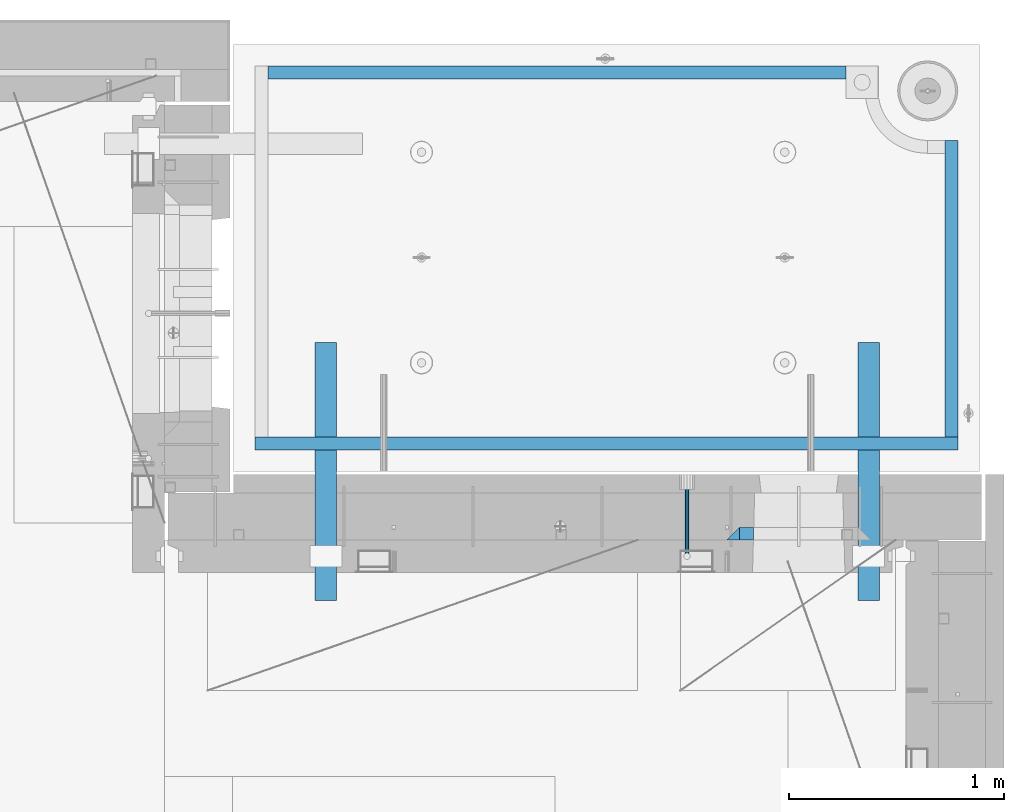
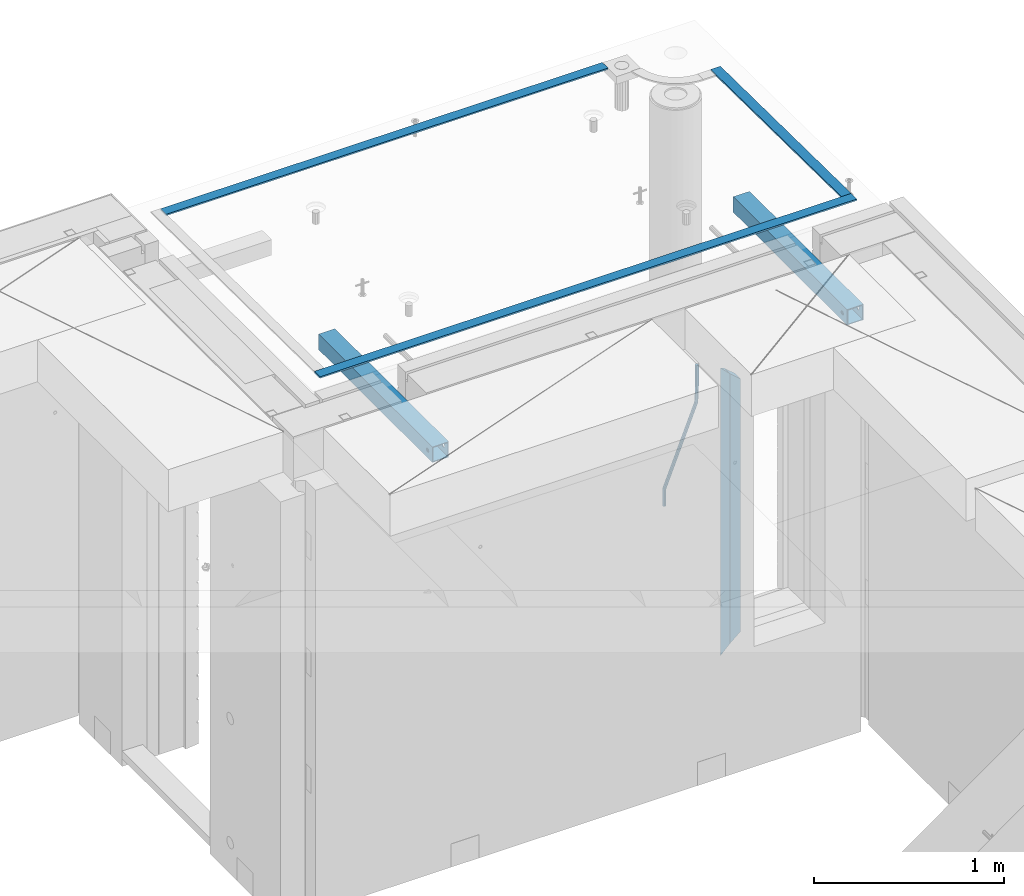
# One storey, part 130 of 341: 8 beams, 4 elements without a shape of their own.
"""IFC2X3 building model written with IfcOpenShell, lengths in millimetres."""

from ifc_helpers import new_model, si_unit, frame, origin_with_axes, place, context, subcontext, project, spatial, faceted_brep, material, type_object, element, aggregate, save


model = new_model("IFC2X3")

# Units and contexts
model_context = context("Model", 3, precision=1e-05, world=origin_with_axes())
body_context = subcontext(model_context, "Body", "Model", "MODEL_VIEW")
ifc_project = project(units=[si_unit("LENGTHUNIT", "METRE", prefix="MILLI"), si_unit("AREAUNIT", "SQUARE_METRE"), si_unit("VOLUMEUNIT", "CUBIC_METRE"), si_unit("MASSUNIT", "GRAM", prefix="KILO"), si_unit("TIMEUNIT", "SECOND"), si_unit("PLANEANGLEUNIT", "RADIAN"), si_unit("SOLIDANGLEUNIT", "STERADIAN"), si_unit("THERMODYNAMICTEMPERATUREUNIT", "DEGREE_CELSIUS"), si_unit("LUMINOUSINTENSITYUNIT", "LUMEN")], contexts=[model_context])

# Site, building, storey
site_placement = place(None, origin_with_axes())
site = spatial("IfcSite", under=ifc_project, at=site_placement, CompositionType="ELEMENT")
building_placement = place(site_placement, origin_with_axes())
building = spatial("IfcBuilding", under=site, at=building_placement, CompositionType="ELEMENT")
storey_placement = place(building_placement, origin_with_axes())
storey = spatial("IfcBuildingStorey", under=building, at=storey_placement, Name="5", CompositionType="ELEMENT", Elevation=0.0)

# Assembly, beam
assembly_1_placement = place(storey_placement, origin_with_axes())
assembly_1 = element("IfcElementAssembly", 1, at=assembly_1_placement, inside=storey, AssemblyPlace="NOTDEFINED", PredefinedType="REINFORCEMENT_UNIT")
ifc_material_1 = material()
beam_type_1 = type_object("IfcBeamType", Name="D20", PredefinedType="NOTDEFINED")
beam_1_placement = place(assembly_1_placement, frame((33889.995187329, 20504.9951872346, 96407.5), z_axis=(0.000415599999849905, 0.999999913638203, 4.76000000899737e-07), x_axis=(0.0, 0.0, -1.0)))
beam_1 = element("IfcBeam", 2, at=beam_1_placement, type_object=beam_type_1, material=ifc_material_1, Name="JM20", ObjectType="D20", context=body_context, shape_type="Brep", body=[
    faceted_brep([(-0.00060564729210455, -9.99999998165731, 0.0), (-0.000428079845733009, -7.07106779890455, -7.07106781186667), (119.575515501536, -7.07830994756296, -7.07106481604933), (119.575337932896, -10.0072421307195, -3.43332612828817e-06), (0.0, 0.0, -10.0), (119.575943836026, -0.00724214867295814, -9.99999700418266), (0.00042843479604926, 7.07106779888636, -7.07106781186303), (119.57637202373, 7.06382565022977, -7.07106481604933), (0.00060564729210455, 9.99999998166459, 3.63797880709171e-12), (119.576549238118, 9.99275783300072, 2.99581552098971e-06), (0.000428079845733009, 7.07106779890819, 7.07106781186667), (119.576371669405, 7.06382565024978, 7.07107080768037), (0.0, 0.0, 10.0), (119.57594333493, -0.00724214864203532, 10.0000029958155), (-0.000428434810601175, -7.07106779888272, 7.07106781186667), (119.575515147211, -7.07830994754295, 7.07107080768037), (123.00654325854, -7.07836650239551, -6.96786008391246), (122.581588830741, -10.007295666459, 0.0904344953341933), (123.182419066041, -0.00729994480025198, -9.89151006310021), (123.006190977103, 7.06376911688858, -6.96788735351402), (122.581091016109, 9.99270432680532, 0.0903895128230943), (122.156136974867, 7.06377516229986, 7.14867767459873), (121.980261167351, -0.00729139528993983, 10.0723276537792), (122.156489256289, -7.07836045697513, 7.14870494419847), (237.077376207715, -7.07551629289992, -0.0988779924864502), (236.652422053201, -10.0044409119728, 6.95941204931296), (237.253252288647, -0.0044516184279928, -3.02253250974718), (237.077024472936, 7.06661932641327, -0.0989143382521434), (236.651924624995, 9.99555908263574, 6.95936064834314), (236.226970470365, 7.06663446442326, 14.0176506898479), (236.051094389448, -0.0044302100486675, 16.9413052071086), (236.227322205144, -7.07550115488812, 14.0176870356117), (256.715938387759, -7.07353516174771, 4.66794781703175), (253.858321224223, -10.0027051854922, 11.1357628166734), (257.898622435067, -0.00236892073007766, 1.98867362452802), (256.713573090979, 7.0686002544353, 4.66742272414376), (253.85497618909, 9.99729452004976, 11.1350202234971), (250.997359025234, 7.06812449537756, 17.6028352234607), (249.814674977912, -0.00304174564189452, 20.2821094159572), (250.999724322028, -7.07401092080545, 17.6033603163596), (1009.84102825288, -6.93521658215468, 337.477148757798), (1006.98341108896, -9.86438660663771, 343.944963757851), (1011.02371230032, 0.135949658781101, 334.7978745651), (1009.83866295629, 7.20691883402651, 337.476623664521), (1006.98006605446, 10.1356130998429, 343.944221163818), (1004.12244889054, 7.2064430753635, 350.412036163872), (1002.9397648431, 0.135276834424076, 353.091310356571), (1004.12481418712, -6.93569234081951, 350.412561257146), (1010.86335274603, -6.9350288225487, 337.928918327354), (1009.37086865908, -9.86394812736762, 344.999991477531), (1011.48104818776, 0.136033652863262, 334.999973251377), (1010.86211737194, 7.20710680115553, 337.928892551665), (1009.36912157628, 10.1360518725905, 344.9999550252), (1007.87663748935, 7.2071325677698, 352.071028175378), (1007.2589420476, 0.13607009235966, 354.999973251352), (1007.87787286344, -6.93500305593261, 352.071053951067), (1011.98104820926, -6.93502881915083, 337.92891832735), (1011.98104821818, -9.86394811943501, 344.999991477524), (1011.98104818776, 0.136033654382118, 334.999973251375), (1011.98104816627, 7.20710680455704, 337.928892551661), (1011.98104815738, 10.1360518805304, 344.999955025194), (1011.98104816629, 7.20713258024625, 352.071028175369), (1011.98104818778, 0.136070106711486, 354.999973251342), (1011.98104820927, -6.9350030434598, 352.071053951058), (1117.50000002154, -6.93502849844299, 337.928918327156), (1117.50000003044, -9.86394779872717, 344.999991477331), (1117.50000000004, 0.136033975091777, 334.999973251181), (1117.49999997855, 7.20710712526488, 337.928892551467), (1117.49999996964, 10.1360522012383, 344.999955025), (1117.49999997857, 7.20713290095409, 352.071028175174), (1117.50000000006, 0.136070427419327, 354.999973251148), (1117.50000002155, -6.93500272275196, 352.071053950864)], [[[0, 1, 2, 3]], [[1, 4, 5, 2]], [[4, 6, 7, 5]], [[6, 8, 9, 7]], [[8, 10, 11, 9]], [[10, 12, 13, 11]], [[12, 14, 15, 13]], [[14, 0, 3, 15]], [[14, 12, 10, 8, 6, 4, 1, 0]], [[3, 2, 16, 17]], [[2, 5, 18, 16]], [[5, 7, 19, 18]], [[7, 9, 20, 19]], [[9, 11, 21, 20]], [[11, 13, 22, 21]], [[13, 15, 23, 22]], [[15, 3, 17, 23]], [[17, 16, 24, 25]], [[16, 18, 26, 24]], [[18, 19, 27, 26]], [[19, 20, 28, 27]], [[20, 21, 29, 28]], [[21, 22, 30, 29]], [[22, 23, 31, 30]], [[23, 17, 25, 31]], [[25, 24, 32, 33]], [[24, 26, 34, 32]], [[26, 27, 35, 34]], [[27, 28, 36, 35]], [[28, 29, 37, 36]], [[29, 30, 38, 37]], [[30, 31, 39, 38]], [[31, 25, 33, 39]], [[33, 32, 40, 41]], [[32, 34, 42, 40]], [[34, 35, 43, 42]], [[35, 36, 44, 43]], [[36, 37, 45, 44]], [[37, 38, 46, 45]], [[38, 39, 47, 46]], [[39, 33, 41, 47]], [[41, 40, 48, 49]], [[40, 42, 50, 48]], [[42, 43, 51, 50]], [[43, 44, 52, 51]], [[44, 45, 53, 52]], [[45, 46, 54, 53]], [[46, 47, 55, 54]], [[47, 41, 49, 55]], [[49, 48, 56, 57]], [[48, 50, 58, 56]], [[50, 51, 59, 58]], [[51, 52, 60, 59]], [[52, 53, 61, 60]], [[53, 54, 62, 61]], [[54, 55, 63, 62]], [[55, 49, 57, 63]], [[57, 56, 64, 65]], [[56, 58, 66, 64]], [[58, 59, 67, 66]], [[59, 60, 68, 67]], [[60, 61, 69, 68]], [[61, 62, 70, 69]], [[62, 63, 71, 70]], [[63, 57, 65, 71]], [[66, 67, 68, 69, 70, 71, 65, 64]]]),
])

# Assemblies, beams
assembly_2_placement = place(storey_placement, origin_with_axes())
assembly_2 = element("IfcElementAssembly", 3, at=assembly_2_placement, inside=storey, AssemblyPlace="NOTDEFINED", PredefinedType="REINFORCEMENT_UNIT")
assembly_3_placement = place(assembly_2_placement, origin_with_axes())
assembly_3 = element("IfcElementAssembly", 4, at=assembly_3_placement, AssemblyPlace="NOTDEFINED", PredefinedType="NOTDEFINED")
ifc_material_2 = material(Name="Undefined/350")
beam_type_2 = type_object("IfcBeamType", Name="100X100X5", PredefinedType="NOTDEFINED")
beam_2_placement = place(assembly_3_placement, frame((34735.0001432011, 21500.0034426031, 96555.0), z_axis=(0.0, 0.0, 1.0), x_axis=(-2.2242999997242e-05, -0.999999999752625, 0.0)))
beam_2 = element("IfcBeam", 5, at=beam_2_placement, type_object=beam_type_2, material=ifc_material_2, ObjectType="100X100X5", context=body_context, shape_type="Brep", body=[
    faceted_brep([(1143.75108023171, 44.9999999999982, -10.8253175473074), (1143.75107855316, 50.0255964196231, -10.8253175473074), (1139.17576100585, 50.0255948914664, -6.25), (1139.1757626844, 44.9999999999982, -6.25), (1150.00108023171, 44.9999999999982, -12.5), (1150.00107855316, 50.0255985071226, -12.5), (1156.2510802317, 44.9999999999982, -10.8253175473074), (1156.25107855315, 50.0256005946221, -10.8253175473074), (1160.82639777901, 44.9999999999982, -6.25), (1160.82639610046, 50.0256021227788, -6.25), (1162.50108023171, 44.9999999999982, 0.0), (1162.50107855316, 50.0256026821226, 0.0), (1160.82639777901, 44.9999999999982, 6.25), (1160.82639610046, 50.0256021227788, 6.25), (1156.2510802317, 44.9999999999982, 10.8253175473074), (1156.25107855315, 50.0256005946221, 10.8253175473074), (1150.00108023171, 44.9999999999982, 12.5), (1150.00107855316, 50.0255985071226, 12.5), (1143.75108023171, 44.9999999999982, 10.8253175473074), (1143.75107855316, 50.0255964196231, 10.8253175473074), (1139.1757626844, 44.9999999999982, 6.25), (1139.17576100585, 50.0255948914664, 6.25), (1137.5010802317, 44.9999999999982, 0.0), (1137.50107855316, 50.0255943321226, 0.0), (1143.75111195316, -49.9744035792783, -10.8253175473074), (1143.75111029171, -44.9999999999991, -10.8253175473074), (1139.1757927444, -44.9999999999991, -6.25), (1139.17579440585, -49.9744051074349, -6.25), (1150.00111195316, -49.9744014917787, -12.5), (1150.00111029171, -44.9999999999991, -12.5), (1156.25111195316, -49.9743994042774, -10.8253175473074), (1156.25111029171, -44.9999999999991, -10.8253175473074), (1160.82642950046, -49.9743978761207, -6.25), (1160.82642783901, -44.9999999999991, -6.25), (1162.50111195316, -49.9743973167779, 0.0), (1162.50111029171, -44.9999999999991, 0.0), (1160.82642950046, -49.9743978761207, 6.25), (1160.82642783901, -44.9999999999991, 6.25), (1156.25111195316, -49.9743994042774, 10.8253175473074), (1156.25111029171, -44.9999999999991, 10.8253175473074), (1150.00111195316, -49.9744014917787, 12.5), (1150.00111029171, -44.9999999999991, 12.5), (1143.75111195316, -49.9744035792783, 10.8253175473074), (1143.75111029171, -44.9999999999991, 10.8253175473074), (1139.17579440585, -49.9744051074349, 6.25), (1139.1757927444, -44.9999999999991, 6.25), (1137.50111195316, -49.9744056667778, 0.0), (1137.50111029171, -44.9999999999991, 0.0), (1.81898940354586e-12, -50.0000000000009, -50.0), (1.81898940354586e-12, 49.9999999999991, -50.0), (1200.00449189278, 49.9999999999982, -50.0), (1200.00449189278, -50.0000000000009, -50.0), (1.81898940354586e-12, 49.9999999999991, 50.0), (1.81898940354586e-12, -50.0000000000009, 50.0), (1200.00449189278, -50.0000000000009, 50.0), (1200.00449189278, 49.9999999999982, 50.0), (0.0, 44.9999999999991, 45.0), (1.81898940354586e-12, -45.0000000000009, 45.0), (1.81898940354586e-12, -45.0000000000009, -45.0), (0.0, 44.9999999999991, -45.0), (1200.00449189278, 44.9999999999982, -45.0), (1200.00449189278, 44.9999999999982, 45.0), (1200.00449189278, -45.0000000000009, 45.0), (1200.00449189278, -45.0000000000009, -45.0)], [[[0, 1, 2, 3]], [[4, 5, 1, 0]], [[6, 7, 5, 4]], [[8, 9, 7, 6]], [[10, 11, 9, 8]], [[12, 13, 11, 10]], [[14, 15, 13, 12]], [[16, 17, 15, 14]], [[18, 19, 17, 16]], [[20, 21, 19, 18]], [[22, 23, 21, 20]], [[3, 2, 23, 22]], [[24, 25, 26, 27]], [[28, 29, 25, 24]], [[30, 31, 29, 28]], [[32, 33, 31, 30]], [[34, 35, 33, 32]], [[36, 37, 35, 34]], [[38, 39, 37, 36]], [[40, 41, 39, 38]], [[42, 43, 41, 40]], [[44, 45, 43, 42]], [[46, 47, 45, 44]], [[27, 26, 47, 46]], [[48, 49, 50, 51]], [[52, 53, 54, 55]], [[49, 52, 55, 50], [15, 17, 19, 21, 23, 2, 1, 5, 7, 9, 11, 13]], [[48, 53, 52, 49], [56, 57, 58, 59]], [[56, 59, 60, 61], [6, 4, 0, 3, 22, 20, 18, 16, 14, 12, 10, 8]], [[57, 56, 61, 62]], [[58, 57, 62, 63], [39, 41, 43, 45, 47, 26, 25, 29, 31, 33, 35, 37]], [[59, 58, 63, 60]], [[54, 51, 50, 55], [62, 61, 60, 63]], [[53, 48, 51, 54], [30, 28, 24, 27, 46, 44, 42, 40, 38, 36, 34, 32]]]),
])
aggregate(assembly_3, [beam_2])
assembly_4_placement = place(assembly_2_placement, origin_with_axes())
assembly_4 = element("IfcElementAssembly", 6, at=assembly_4_placement, AssemblyPlace="NOTDEFINED", PredefinedType="NOTDEFINED")
beam_3_placement = place(assembly_4_placement, frame((32210.0001432011, 21500.0034426031, 96555.0), z_axis=(0.0, 0.0, 1.0), x_axis=(-2.2242999997242e-05, -0.999999999752625, 0.0)))
beam_3 = element("IfcBeam", 7, at=beam_3_placement, type_object=beam_type_2, material=ifc_material_2, ObjectType="100X100X5", context=body_context, shape_type="Brep", body=[
    faceted_brep([(1143.75108023171, 44.9999999999982, -10.8253175473074), (1143.75107855316, 50.0255964196231, -10.8253175473074), (1139.17576100585, 50.0255948914664, -6.25), (1139.1757626844, 44.9999999999982, -6.25), (1150.00108023171, 44.9999999999982, -12.5), (1150.00107855316, 50.0255985071226, -12.5), (1156.2510802317, 44.9999999999982, -10.8253175473074), (1156.25107855315, 50.0256005946221, -10.8253175473074), (1160.82639777901, 44.9999999999982, -6.25), (1160.82639610046, 50.0256021227788, -6.25), (1162.50108023171, 44.9999999999982, 0.0), (1162.50107855316, 50.0256026821226, 0.0), (1160.82639777901, 44.9999999999982, 6.25), (1160.82639610046, 50.0256021227788, 6.25), (1156.2510802317, 44.9999999999982, 10.8253175473074), (1156.25107855315, 50.0256005946221, 10.8253175473074), (1150.00108023171, 44.9999999999982, 12.5), (1150.00107855316, 50.0255985071226, 12.5), (1143.75108023171, 44.9999999999982, 10.8253175473074), (1143.75107855316, 50.0255964196231, 10.8253175473074), (1139.1757626844, 44.9999999999982, 6.25), (1139.17576100585, 50.0255948914664, 6.25), (1137.5010802317, 44.9999999999982, 0.0), (1137.50107855316, 50.0255943321226, 0.0), (1143.75111195316, -49.9744035792783, -10.8253175473074), (1143.75111029171, -44.9999999999991, -10.8253175473074), (1139.1757927444, -44.9999999999991, -6.25), (1139.17579440585, -49.9744051074349, -6.25), (1150.00111195316, -49.9744014917787, -12.5), (1150.00111029171, -44.9999999999991, -12.5), (1156.25111195316, -49.9743994042774, -10.8253175473074), (1156.25111029171, -44.9999999999991, -10.8253175473074), (1160.82642950046, -49.9743978761207, -6.25), (1160.82642783901, -44.9999999999991, -6.25), (1162.50111195316, -49.9743973167779, 0.0), (1162.50111029171, -44.9999999999991, 0.0), (1160.82642950046, -49.9743978761207, 6.25), (1160.82642783901, -44.9999999999991, 6.25), (1156.25111195316, -49.9743994042774, 10.8253175473074), (1156.25111029171, -44.9999999999991, 10.8253175473074), (1150.00111195316, -49.9744014917787, 12.5), (1150.00111029171, -44.9999999999991, 12.5), (1143.75111195316, -49.9744035792783, 10.8253175473074), (1143.75111029171, -44.9999999999991, 10.8253175473074), (1139.17579440585, -49.9744051074349, 6.25), (1139.1757927444, -44.9999999999991, 6.25), (1137.50111195316, -49.9744056667778, 0.0), (1137.50111029171, -44.9999999999991, 0.0), (1.81898940354586e-12, -50.0000000000009, -50.0), (1.81898940354586e-12, 49.9999999999991, -50.0), (1200.00449189278, 49.9999999999982, -50.0), (1200.00449189278, -50.0000000000009, -50.0), (1.81898940354586e-12, 49.9999999999991, 50.0), (1.81898940354586e-12, -50.0000000000009, 50.0), (1200.00449189278, -50.0000000000009, 50.0), (1200.00449189278, 49.9999999999982, 50.0), (0.0, 44.9999999999991, 45.0), (1.81898940354586e-12, -45.0000000000009, 45.0), (1.81898940354586e-12, -45.0000000000009, -45.0), (0.0, 44.9999999999991, -45.0), (1200.00449189278, 44.9999999999982, -45.0), (1200.00449189278, 44.9999999999982, 45.0), (1200.00449189278, -45.0000000000009, 45.0), (1200.00449189278, -45.0000000000009, -45.0)], [[[0, 1, 2, 3]], [[4, 5, 1, 0]], [[6, 7, 5, 4]], [[8, 9, 7, 6]], [[10, 11, 9, 8]], [[12, 13, 11, 10]], [[14, 15, 13, 12]], [[16, 17, 15, 14]], [[18, 19, 17, 16]], [[20, 21, 19, 18]], [[22, 23, 21, 20]], [[3, 2, 23, 22]], [[24, 25, 26, 27]], [[28, 29, 25, 24]], [[30, 31, 29, 28]], [[32, 33, 31, 30]], [[34, 35, 33, 32]], [[36, 37, 35, 34]], [[38, 39, 37, 36]], [[40, 41, 39, 38]], [[42, 43, 41, 40]], [[44, 45, 43, 42]], [[46, 47, 45, 44]], [[27, 26, 47, 46]], [[48, 49, 50, 51]], [[52, 53, 54, 55]], [[49, 52, 55, 50], [15, 17, 19, 21, 23, 2, 1, 5, 7, 9, 11, 13]], [[48, 53, 52, 49], [56, 57, 58, 59]], [[56, 59, 60, 61], [6, 4, 0, 3, 22, 20, 18, 16, 14, 12, 10, 8]], [[57, 56, 61, 62]], [[58, 57, 62, 63], [39, 41, 43, 45, 47, 26, 25, 29, 31, 33, 35, 37]], [[59, 58, 63, 60]], [[54, 51, 50, 55], [62, 61, 60, 63]], [[53, 48, 51, 54], [30, 28, 24, 27, 46, 44, 42, 40, 38, 36, 34, 32]]]),
])
aggregate(assembly_4, [beam_3])
ifc_material_3 = material(Name="CONCRETE/Concrete_Undefined")
beam_type_3 = type_object("IfcBeamType", PredefinedType="NOTDEFINED")
beam_4_placement = place(assembly_2_placement, frame((31939.9962088653, 22755.0460044164, 96704.8214945677), z_axis=(-6.06120000110142e-05, 1.00000033869885e-09, 0.999999998163093), x_axis=(0.999999998046552, -1.52670000006885e-05, 6.06120000021532e-05)))
beam_4 = element("IfcBeam", 8, at=beam_4_placement, type_object=beam_type_3, material=ifc_material_3, context=body_context, shape_type="Brep", body=[
    faceted_brep([(2.5465851649642e-11, 29.9999999999982, -4.99999999998545), (-2.91038304567337e-11, 29.9999999999982, 5.0), (2689.99575395095, 29.9999999999964, 5.0), (2689.99575395095, 30.0000000000036, -4.99999999998545), (-2.5465851649642e-11, -30.0000000000018, 5.0), (2689.99575395095, -30.0000000000036, 5.00000000001455), (2.72848410531878e-11, -30.0000000000018, -4.99999999998545), (2689.99575395095, -29.9999999999964, -4.99999999998545)], [[[0, 1, 2, 3]], [[1, 4, 5, 2]], [[4, 6, 7, 5]], [[6, 0, 3, 7]], [[5, 7, 3, 2]], [[6, 4, 1, 0]]]),
])
beam_5_placement = place(assembly_2_placement, frame((35120.0586113047, 21059.9283388168, 96725.6638339053), z_axis=(-5.46000002942176e-07, 0.0130421150000144, 0.999914948001093), x_axis=(-4.18520000064741e-05, 0.999914947125351, -0.0130421150016393)))
beam_5 = element("IfcBeam", 9, at=beam_5_placement, type_object=beam_type_3, material=ifc_material_3, context=body_context, shape_type="Brep", body=[
    faceted_brep([(2.5465851649642e-11, 29.9999999999982, -4.99999999998545), (-2.91038304567337e-11, 29.9999999999982, 5.0), (1380.14316164461, 30.0, 5.00000000001455), (1380.1431616447, 29.9999999999927, -5.0), (-2.5465851649642e-11, -30.0000000000018, 5.0), (1380.14316164461, -30.0, 5.00000000001455), (2.72848410531878e-11, -30.0000000000018, -4.99999999998545), (1380.1431616447, -30.0, -5.0)], [[[0, 1, 2, 3]], [[1, 4, 5, 2]], [[4, 6, 7, 5]], [[6, 0, 3, 7]], [[5, 7, 3, 2]], [[6, 4, 1, 0]]]),
])
beam_6_placement = place(assembly_2_placement, frame((31879.9986204165, 21030.068155681, 96725.2788443041), z_axis=(-0.000117617000009658, 3.00000101585662e-09, 0.999999993083121), x_axis=(0.999999992839137, -2.20899999960382e-05, 0.000117616999982089)))
beam_6 = element("IfcBeam", 10, at=beam_6_placement, type_object=beam_type_3, material=ifc_material_3, context=body_context, shape_type="Brep", body=[
    faceted_brep([(2.5465851649642e-11, 29.9999999999982, -4.99999999998545), (-2.91038304567337e-11, 29.9999999999982, 5.0), (3270.06002088557, 30.0, 5.0), (3270.06002088557, 30.0000000000036, -5.0), (-2.5465851649642e-11, -30.0000000000018, 5.0), (3270.06002088557, -30.0, 5.0), (2.72848410531878e-11, -30.0000000000018, -4.99999999998545), (3270.06002088558, -29.9999999999964, -5.0)], [[[0, 1, 2, 3]], [[1, 4, 5, 2]], [[4, 6, 7, 5]], [[6, 0, 3, 7]], [[5, 7, 3, 2]], [[6, 4, 1, 0]]]),
])
aggregate(assembly_2, [assembly_3, assembly_4, beam_4, beam_5, beam_6])

# Beam
ifc_material_4 = material(Name="CONCRETE/C25/30")
beam_type_4 = type_object("IfcBeamType", PredefinedType="NOTDEFINED")
beam_7_placement = place(assembly_1_placement, frame((34105.0055090716, 20609.9951872276, 96275.0), z_axis=(1.0, 0.0, 0.0), x_axis=(0.0, 0.0, -1.0)))
beam_7 = element("IfcBeam", 11, at=beam_7_placement, type_object=beam_type_4, material=ifc_material_4, Name="SK", context=body_context, shape_type="Brep", body=[
    faceted_brep([(60.0000000000073, 30.0, 30.0), (0.0, -30.0, -30.0), (60.0000000000073, -30.0, 30.0), (1795.00000000001, 30.0, 30.0), (1855.0, -30.0, -30.0), (1795.00000000001, -30.0, 30.0)], [[[0, 1, 2]], [[3, 4, 1, 0]], [[4, 5, 2, 1]], [[5, 3, 0, 2]], [[5, 4, 3]]]),
])

beam_type_5 = type_object("IfcBeamType", PredefinedType="NOTDEFINED")
beam_8_placement = place(assembly_1_placement, frame((34170.0055090716, 20609.9951872276, 96215.0), z_axis=(1.0, 0.0, 0.0), x_axis=(0.0, 0.0, -1.0)))
beam_8 = element("IfcBeam", 12, at=beam_8_placement, type_object=beam_type_5, material=ifc_material_4, Name="SK", context=body_context, shape_type="Brep", body=[
    faceted_brep([(0.0, -30.0, -35.0), (54.9034748914273, -30.0, 29.0540540540533), (56.2934362811066, 30.0, 30.6756756756768), (0.0, 30.0, -35.0), (1678.70656371891, 30.0, 30.6756756756768), (1735.0, 30.0, -35.0), (1735.0, -30.0, -35.0), (1680.09652510857, -30.0, 29.0540540540533)], [[[0, 1, 2, 3]], [[3, 2, 4, 5]], [[5, 6, 0, 3]], [[1, 0, 6, 7]], [[2, 1, 7, 4]], [[6, 5, 4, 7]]]),
])

aggregate(assembly_1, [beam_1, beam_8, beam_7])

save(model, "model.ifc")
